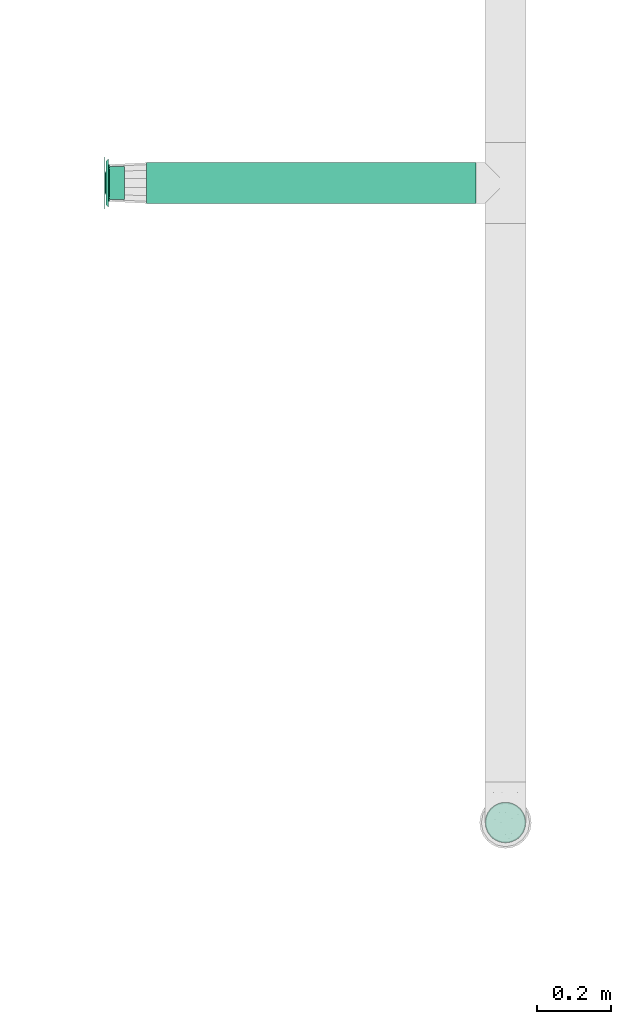
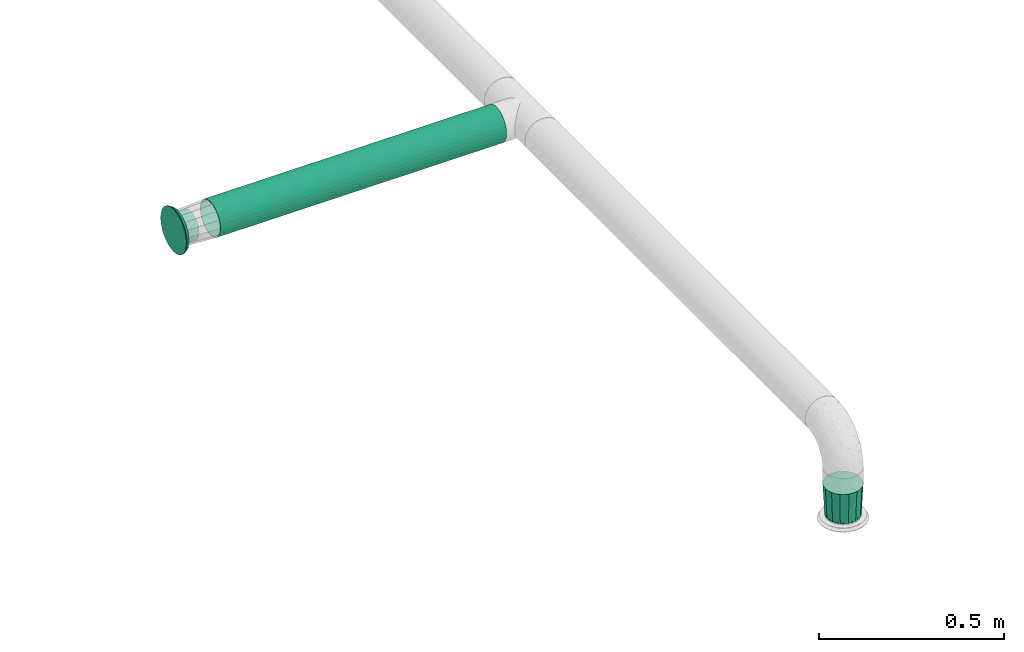
# One storey, part 39 of 115: 1 flow fitting, 1 flow segment, 1 flow terminal.
"""IFC2X3 building model written with IfcOpenShell, lengths in millimetres."""

from ifc_helpers import new_model, entity, si_unit, converted_unit, derived_unit, direction, frame, origin_with_axes, origin_2d_with_axis, place, context, subcontext, project, spatial, hollow_circle, extrude, open_shell, surface_model, source, transform, mapped, material, layer, layer_set, layer_usage, type_object, element, save


model = new_model("IFC2X3")

# Units and contexts
model_context = context("Model", 3, precision=1e-05, world=origin_with_axes(), true_north=direction((0.0, 1.0)))
body_context = subcontext(model_context, "Body", "Model", "MODEL_VIEW")
ifc_project = project(units=[si_unit("AREAUNIT", "SQUARE_METRE"), si_unit("VOLUMEUNIT", "CUBIC_METRE", prefix="DECI"), si_unit("TIMEUNIT", "SECOND"), si_unit("THERMODYNAMICTEMPERATUREUNIT", "DEGREE_CELSIUS"), si_unit("PRESSUREUNIT", "PASCAL"), si_unit("MASSUNIT", "GRAM", prefix="KILO"), si_unit("LENGTHUNIT", "METRE", prefix="MILLI"), si_unit("POWERUNIT", "WATT"), si_unit("ELECTRICCURRENTUNIT", "AMPERE"), si_unit("ELECTRICVOLTAGEUNIT", "VOLT"), derived_unit("VOLUMETRICFLOWRATEUNIT", [(si_unit("VOLUMEUNIT", "CUBIC_METRE", prefix="DECI"), 1), (si_unit("TIMEUNIT", "SECOND"), -1)]), derived_unit("LINEARVELOCITYUNIT", [(si_unit("LENGTHUNIT", "METRE"), 1), (si_unit("TIMEUNIT", "SECOND"), -1)]), derived_unit("MASSDENSITYUNIT", [(si_unit("MASSUNIT", "GRAM", prefix="KILO"), 1), (si_unit("VOLUMEUNIT", "CUBIC_METRE"), -1)]), converted_unit("PLANEANGLEUNIT", "DEGREE", entity("IfcRatioMeasure", 0.01745), si_unit("PLANEANGLEUNIT", "RADIAN"), dimensions=[0, 0, 0, 0, 0, 0, 0])], contexts=[model_context])

# Site, building, storey
site_placement = place(None, origin_with_axes())
site = spatial("IfcSite", under=ifc_project, at=site_placement, CompositionType="ELEMENT")
building_placement = place(site_placement, origin_with_axes())
building = spatial("IfcBuilding", under=site, at=building_placement, Name="mc-building", CompositionType="ELEMENT")
storey_placement = place(building_placement, frame((0.0, 0.0, 2950.0), z_axis=(0.0, 0.0, 1.0), x_axis=(1.0, 0.0, 0.0)))
storey = spatial("IfcBuildingStorey", under=building, at=storey_placement, Name="2. Korrus", CompositionType="ELEMENT", Elevation=2950.0)

# Flow terminal
air_terminal_type = type_object("IfcAirTerminalType", Name="100", PredefinedType="NOTDEFINED")
shared_shape_1 = source(origin_with_axes(), body_context, "Body", "SurfaceModel", [
    surface_model("IfcShellBasedSurfaceModel", [(11.2, 18.11733, -67.61481), (11.2, -18.11733, -67.61481), (11.2, 0.0, -70.0), (11.2, 67.61481, -18.11733), (11.2, 35.0, -60.62178), (11.2, 49.49747, -49.49747), (11.2, 60.62178, -35.0), (11.2, -67.61481, 18.11733), (11.2, -49.49747, -49.49747), (11.2, -67.61481, -18.11733), (11.2, -35.0, -60.62178), (11.2, -60.62178, -35.0), (11.2, -70.0, 0.0), (11.2, 18.11733, 67.61481), (11.2, 70.0, 0.0), (11.2, 67.61481, 18.11733), (11.2, 49.49747, 49.49747), (11.2, 60.62178, 35.0), (11.2, 35.0, 60.62178), (11.2, -49.49747, 49.49747), (11.2, -60.62178, 35.0), (11.2, -35.0, 60.62178), (11.2, -18.11733, 67.61481), (11.2, 0.0, 70.0), (9.2, 18.11733, 67.61481), (9.2, -67.61481, 18.11733), (9.2, 0.0, 70.0), (9.2, 49.49747, 49.49747), (9.2, 35.0, 60.62178), (9.2, 60.62178, 35.0), (9.2, 67.61481, 18.11733), (9.2, -35.0, 60.62178), (9.2, -49.49747, 49.49747), (9.2, -18.11733, 67.61481), (9.2, -60.62178, 35.0), (9.2, -67.61481, -18.11733), (9.2, -70.0, 0.0), (9.2, 67.61481, -18.11733), (9.2, 18.11733, -67.61481), (9.2, 49.49747, -49.49747), (9.2, 60.62178, -35.0), (9.2, 35.0, -60.62178), (9.2, -18.11733, -67.61481), (9.2, -49.49747, -49.49747), (9.2, -60.62178, -35.0), (9.2, -35.0, -60.62178), (9.2, 0.0, -70.0), (9.2, 70.0, 0.0), (9.2, 32.75, 0.0), (9.2, -16.375, 28.36233), (9.2, -28.36233, 16.375), (9.2, 16.375, 28.36233), (9.2, 0.0, 32.75), (9.2, 28.36233, 16.375), (9.2, -32.75, 0.0), (9.2, -16.375, -28.36233), (9.2, 16.375, -28.36233), (9.2, 0.0, -32.75), (9.2, 28.36233, -16.375), (9.2, -28.36233, -16.375), (6.2, -21.19625, -15.39997), (6.2, -21.19625, 15.39997), (6.2, 8.09625, 24.91768), (6.2, -8.09625, 24.91768), (6.2, -26.2, 0.0), (6.2, 21.19625, 15.39997), (6.2, -8.09625, -24.91768), (6.2, 21.19625, -15.39997), (6.2, 8.09625, -24.91768), (6.2, 26.2, 0.0), (9.2, 31.06579, -6.28555), (6.2, 23.69812, -7.69999), (6.2, -14.64625, -20.15883), (9.2, -22.36867, -22.36867), (6.2, -23.69812, -7.69999), (9.2, -31.06579, -6.28555), (6.2, 14.64625, -20.15883), (9.2, 8.1875, -30.55617), (6.2, 0.0, -24.91768), (9.2, 22.36867, -22.36867), (9.2, -8.1875, -30.55617), (9.2, -31.06579, 6.28555), (6.2, -23.69812, 7.69999), (6.2, 14.64625, 20.15883), (9.2, 22.36867, 22.36867), (6.2, 23.69812, 7.69999), (9.2, 31.06579, 6.28555), (6.2, -14.64625, 20.15883), (9.2, -8.1875, 30.55617), (6.2, 0.0, 24.91768), (9.2, -22.36867, 22.36867), (9.2, 8.1875, 30.55617), (6.2, -13.11761, 57.472), (6.2, -36.75472, 46.08897), (6.2, -53.11211, 25.57744), (6.2, 36.75472, 46.08897), (6.2, -58.95, 0.0), (6.2, 13.11761, 57.472), (6.2, 53.11211, 25.57744), (6.2, -53.11211, -25.57744), (6.2, -36.75472, -46.08897), (6.2, -13.11761, -57.472), (6.2, 58.95, 0.0), (6.2, 53.11211, -25.57744), (6.2, 13.11761, -57.472), (6.2, 36.75472, -46.08897), (0.0, -60.51411, 25.06576), (0.0, 0.0, 65.5), (0.0, 25.06576, 60.51411), (0.0, 46.3155, 46.3155), (0.0, 60.51411, 25.06576), (0.0, -46.3155, 46.3155), (0.0, -25.06576, 60.51411), (0.0, 0.0, -65.5), (0.0, -65.5, 0.0), (0.0, 65.5, 0.0), (0.0, 60.51411, -25.06576), (0.0, 46.3155, -46.3155), (0.0, 25.06576, -60.51411), (0.0, -46.3155, -46.3155), (0.0, -60.51411, -25.06576), (0.0, -25.06576, -60.51411), (6.2, 56.03105, -12.78872), (0.0, 53.4148, -35.69063), (0.0, 35.69063, -53.4148), (6.2, 24.93616, -51.78048), (0.0, -12.53288, -63.00706), (6.2, 0.0, -57.472), (0.0, -35.69063, -53.4148), (0.0, 63.00706, -12.53288), (6.2, 44.93342, -35.83321), (6.2, -24.93616, -51.78048), (6.2, -44.93342, -35.83321), (0.0, -53.4148, -35.69063), (0.0, 12.53288, -63.00706), (6.2, -56.03105, -12.78872), (0.0, -63.00706, -12.53288), (6.2, -56.03105, 12.78872), (0.0, -53.4148, 35.69063), (0.0, -35.69063, 53.4148), (6.2, -24.93616, 51.78048), (0.0, 12.53288, 63.00706), (6.2, 0.0, 57.472), (0.0, 35.69063, 53.4148), (0.0, -63.00706, 12.53288), (6.2, -44.93342, 35.83321), (6.2, 24.93616, 51.78048), (6.2, 44.93342, 35.83321), (0.0, 53.4148, 35.69063), (0.0, -12.53288, 63.00706), (6.2, 56.03105, 12.78872), (0.0, 63.00706, 12.53288), (-3.1, 12.94095, 48.29629), (-3.1, -35.35534, 35.35534), (-3.1, 0.0, 50.0), (-3.1, 35.35534, 35.35534), (-3.1, 25.0, 43.30127), (-3.1, -43.30127, 25.0), (-3.1, 43.30127, 25.0), (-3.1, -48.29629, -12.94095), (-3.1, -12.94095, 48.29629), (-3.1, -25.0, 43.30127), (-3.1, -50.0, 0.0), (-3.1, -48.29629, 12.94095), (-3.1, 48.29629, 12.94095), (-3.1, 12.94095, -48.29629), (-3.1, 50.0, 0.0), (-3.1, 48.29629, -12.94095), (-3.1, 35.35534, -35.35534), (-3.1, 43.30127, -25.0), (-3.1, 25.0, -43.30127), (-3.1, 0.0, -50.0), (-3.1, -35.35534, -35.35534), (-3.1, -43.30127, -25.0), (-3.1, -25.0, -43.30127), (-3.1, -12.94095, -48.29629), (0.0, 25.0, -43.30127), (0.0, 0.0, -50.0), (0.0, 12.94095, -48.29629), (0.0, 48.29629, -12.94095), (0.0, 35.35534, -35.35534), (0.0, -25.0, -43.30127), (0.0, 43.30127, -25.0), (0.0, -50.0, 0.0), (0.0, -12.94095, -48.29629), (0.0, -35.35534, -35.35534), (0.0, -48.29629, -12.94095), (0.0, -43.30127, -25.0), (0.0, 50.0, 0.0), (0.0, 43.30127, 25.0), (0.0, 12.94095, 48.29629), (0.0, 35.35534, 35.35534), (0.0, 25.0, 43.30127), (0.0, 0.0, 50.0), (0.0, -35.35534, 35.35534), (0.0, -43.30127, 25.0), (0.0, -48.29629, 12.94095), (0.0, -12.94095, 48.29629), (0.0, -25.0, 43.30127), (0.0, 48.29629, 12.94095), (-43.1, 0.0, 45.0), (-43.1, 11.64686, 43.46666), (-43.1, 22.5, 38.97115), (-43.1, -11.64686, 43.46666), (-43.1, 38.97115, 22.5), (-43.1, 43.46666, 11.64686), (-43.1, 31.81981, 31.81981), (-43.1, -22.5, 38.97115), (-43.1, -43.46666, 11.64686), (-43.1, -31.81981, 31.81981), (-43.1, -38.97115, 22.5), (-43.1, -45.0, 0.0), (-43.1, -43.46666, -11.64686), (-43.1, 45.0, 0.0), (-43.1, 43.46666, -11.64686), (-43.1, 38.97115, -22.5), (-43.1, 31.81981, -31.81981), (-43.1, 22.5, -38.97115), (-43.1, 11.64686, -43.46666), (-43.1, -31.81981, -31.81981), (-43.1, -38.97115, -22.5), (-43.1, -22.5, -38.97115), (-43.1, 0.0, -45.0), (-43.1, -11.64686, -43.46666), (-3.1, 22.5, -38.97115), (-3.1, 0.0, -45.0), (-3.1, 11.64686, -43.46666), (-3.1, 31.81981, -31.81981), (-3.1, -22.5, -38.97115), (-3.1, 38.97115, -22.5), (-3.1, 43.46666, -11.64686), (-3.1, 45.0, 0.0), (-3.1, -45.0, 0.0), (-3.1, -11.64686, -43.46666), (-3.1, -31.81981, -31.81981), (-3.1, -43.46666, -11.64686), (-3.1, -38.97115, -22.5), (-3.1, 0.0, 45.0), (-3.1, 43.46666, 11.64686), (-3.1, 38.97115, 22.5), (-3.1, 22.5, 38.97115), (-3.1, 31.81981, 31.81981), (-3.1, 11.64686, 43.46666), (-3.1, -11.64686, 43.46666), (-3.1, -43.46666, 11.64686), (-3.1, -31.81981, 31.81981), (-3.1, -38.97115, 22.5), (-3.1, -22.5, 38.97115)], [open_shell([[[0, 1, 2]], [[3, 0, 4]], [[5, 6, 3]], [[5, 3, 4]], [[7, 1, 0]], [[8, 7, 9]], [[10, 7, 8]], [[8, 9, 11]], [[12, 9, 7]], [[1, 7, 10]], [[7, 0, 3]], [[13, 14, 15]], [[16, 15, 17]], [[16, 18, 13]], [[16, 13, 15]], [[14, 13, 7]], [[7, 19, 20]], [[19, 7, 21]], [[7, 22, 21]], [[22, 7, 23]], [[7, 13, 23]], [[14, 7, 3]], [[24, 25, 26]], [[27, 24, 28]], [[27, 29, 30]], [[27, 30, 24]], [[25, 24, 30]], [[31, 25, 32]], [[25, 31, 33]], [[32, 25, 34]], [[33, 26, 25]], [[25, 35, 36]], [[25, 30, 37]], [[25, 37, 38]], [[39, 37, 40]], [[39, 41, 38]], [[39, 38, 37]], [[38, 42, 25]], [[35, 43, 44]], [[35, 25, 43]], [[45, 43, 25]], [[42, 45, 25]], [[38, 46, 42]], [[37, 30, 47]], [[35, 9, 36]], [[44, 11, 35]], [[10, 43, 45]], [[44, 43, 8]], [[1, 45, 42]], [[35, 11, 9]], [[9, 12, 36]], [[1, 10, 45]], [[8, 43, 10]], [[8, 11, 44]], [[2, 1, 42]], [[42, 46, 2]], [[38, 0, 46]], [[41, 4, 38]], [[6, 39, 40]], [[41, 39, 5]], [[3, 40, 37]], [[41, 5, 4]], [[4, 0, 38]], [[14, 3, 37]], [[6, 40, 3]], [[6, 5, 39]], [[47, 14, 37]], [[46, 0, 2]], [[30, 15, 47]], [[29, 17, 30]], [[18, 27, 28]], [[29, 27, 16]], [[13, 28, 24]], [[30, 17, 15]], [[15, 14, 47]], [[13, 18, 28]], [[16, 27, 18]], [[16, 17, 29]], [[23, 13, 24]], [[24, 26, 23]], [[33, 22, 26]], [[31, 21, 33]], [[20, 32, 34]], [[31, 32, 19]], [[7, 34, 25]], [[31, 19, 21]], [[21, 22, 33]], [[12, 7, 25]], [[20, 34, 7]], [[20, 19, 32]], [[36, 12, 25]], [[26, 22, 23]], [[48, 49, 50]], [[48, 51, 49]], [[49, 51, 52]], [[53, 51, 48]], [[48, 50, 54]], [[54, 55, 48]], [[56, 55, 57]], [[55, 58, 48]], [[58, 55, 56]], [[55, 54, 59]], [[60, 61, 62]], [[62, 61, 63]], [[64, 61, 60]], [[62, 65, 66]], [[67, 68, 65]], [[66, 60, 62]], [[65, 68, 66]], [[69, 67, 65]], [[69, 48, 70]], [[58, 71, 70]], [[72, 73, 60]], [[59, 74, 60]], [[75, 64, 74]], [[56, 68, 76]], [[72, 66, 55]], [[73, 72, 55]], [[68, 77, 78]], [[64, 75, 54]], [[59, 75, 74]], [[70, 71, 69]], [[67, 79, 76]], [[80, 55, 66]], [[68, 56, 77]], [[56, 76, 79]], [[79, 67, 58]], [[71, 58, 67]], [[80, 78, 57]], [[77, 57, 78]], [[66, 78, 80]], [[59, 60, 73]], [[64, 54, 81]], [[50, 82, 81]], [[83, 84, 65]], [[53, 85, 65]], [[86, 69, 85]], [[49, 63, 87]], [[83, 62, 51]], [[84, 83, 51]], [[63, 88, 89]], [[69, 86, 48]], [[53, 86, 85]], [[81, 82, 64]], [[61, 90, 87]], [[91, 51, 62]], [[63, 49, 88]], [[49, 87, 90]], [[90, 61, 50]], [[82, 50, 61]], [[91, 89, 52]], [[88, 52, 89]], [[62, 89, 91]], [[53, 65, 84]], [[92, 93, 94]], [[95, 94, 96]], [[97, 92, 95]], [[95, 92, 94]], [[96, 98, 95]], [[96, 99, 98]], [[99, 100, 101]], [[101, 102, 98]], [[102, 101, 103]], [[104, 105, 103]], [[101, 104, 103]], [[101, 98, 99]], [[106, 107, 108]], [[109, 110, 108]], [[106, 108, 110]], [[111, 112, 106]], [[106, 112, 107]], [[106, 113, 114]], [[106, 110, 113]], [[115, 116, 117]], [[117, 113, 110]], [[113, 117, 118]], [[114, 119, 120]], [[121, 119, 114]], [[121, 114, 113]], [[115, 117, 110]], [[103, 116, 122]], [[123, 116, 103]], [[124, 125, 118]], [[101, 126, 127]], [[100, 119, 128]], [[102, 122, 129]], [[103, 130, 123]], [[102, 129, 115]], [[113, 127, 126]], [[125, 124, 105]], [[130, 105, 117]], [[118, 125, 104]], [[124, 117, 105]], [[131, 100, 128]], [[119, 100, 132]], [[133, 99, 120]], [[134, 118, 104]], [[122, 116, 129]], [[127, 134, 104]], [[131, 121, 101]], [[99, 133, 132]], [[128, 121, 131]], [[130, 117, 123]], [[101, 121, 126]], [[99, 135, 120]], [[96, 136, 135]], [[136, 120, 135]], [[134, 127, 113]], [[133, 119, 132]], [[136, 96, 114]], [[94, 106, 137]], [[138, 106, 94]], [[139, 140, 112]], [[97, 141, 142]], [[95, 109, 143]], [[96, 137, 144]], [[94, 145, 138]], [[96, 144, 114]], [[107, 142, 141]], [[140, 139, 93]], [[145, 93, 111]], [[112, 140, 92]], [[139, 111, 93]], [[146, 95, 143]], [[109, 95, 147]], [[148, 98, 110]], [[149, 112, 92]], [[137, 106, 144]], [[142, 149, 92]], [[146, 108, 97]], [[98, 148, 147]], [[143, 108, 146]], [[145, 111, 138]], [[97, 108, 141]], [[98, 150, 110]], [[102, 151, 150]], [[151, 110, 150]], [[149, 142, 107]], [[148, 109, 147]], [[151, 102, 115]], [[152, 153, 154]], [[155, 152, 156]], [[157, 152, 158]], [[158, 152, 155]], [[158, 159, 157]], [[160, 153, 161]], [[160, 154, 153]], [[157, 162, 163]], [[153, 152, 157]], [[157, 159, 162]], [[158, 164, 159]], [[165, 166, 167]], [[168, 167, 169]], [[170, 165, 167]], [[170, 167, 168]], [[166, 165, 171]], [[159, 172, 173]], [[172, 159, 174]], [[174, 171, 175]], [[159, 164, 174]], [[166, 171, 174]], [[174, 164, 166]], [[176, 177, 178]], [[179, 176, 180]], [[176, 179, 181]], [[179, 180, 182]], [[179, 183, 181]], [[177, 181, 184]], [[177, 176, 181]], [[185, 186, 187]], [[186, 185, 181]], [[181, 183, 186]], [[183, 179, 188]], [[183, 188, 189]], [[190, 189, 191]], [[189, 190, 183]], [[190, 191, 192]], [[193, 194, 190]], [[183, 195, 196]], [[183, 190, 195]], [[194, 197, 198]], [[194, 195, 190]], [[197, 194, 193]], [[189, 188, 199]], [[164, 199, 166]], [[158, 189, 164]], [[192, 155, 156]], [[158, 155, 191]], [[190, 156, 152]], [[164, 189, 199]], [[199, 188, 166]], [[190, 192, 156]], [[191, 155, 192]], [[191, 189, 158]], [[193, 190, 152]], [[152, 154, 193]], [[160, 197, 154]], [[161, 198, 160]], [[195, 153, 157]], [[161, 153, 194]], [[196, 157, 163]], [[161, 194, 198]], [[198, 197, 160]], [[183, 196, 163]], [[195, 157, 196]], [[195, 194, 153]], [[162, 183, 163]], [[154, 197, 193]], [[159, 186, 162]], [[173, 187, 159]], [[181, 172, 174]], [[173, 172, 185]], [[184, 174, 175]], [[159, 187, 186]], [[186, 183, 162]], [[184, 181, 174]], [[185, 172, 181]], [[185, 187, 173]], [[177, 184, 175]], [[175, 171, 177]], [[165, 178, 171]], [[170, 176, 165]], [[182, 168, 169]], [[170, 168, 180]], [[179, 169, 167]], [[170, 180, 176]], [[176, 178, 165]], [[188, 179, 167]], [[182, 169, 179]], [[182, 180, 168]], [[166, 188, 167]], [[171, 178, 177]], [[200, 201, 202]], [[203, 200, 202]], [[204, 205, 202]], [[204, 202, 206]], [[203, 202, 205]], [[207, 208, 209]], [[207, 203, 205]], [[209, 208, 210]], [[211, 208, 212]], [[208, 207, 212]], [[207, 205, 212]], [[213, 214, 215]], [[205, 215, 212]], [[212, 216, 217]], [[216, 212, 215]], [[218, 219, 217]], [[212, 219, 220]], [[212, 217, 219]], [[221, 222, 223]], [[222, 221, 219]], [[218, 222, 219]], [[215, 205, 213]], [[224, 225, 226]], [[227, 228, 224]], [[229, 230, 231]], [[228, 227, 229]], [[229, 232, 228]], [[225, 228, 233]], [[225, 224, 228]], [[234, 235, 236]], [[235, 234, 228]], [[228, 232, 235]], [[232, 229, 231]], [[237, 238, 239]], [[240, 239, 241]], [[240, 242, 237]], [[240, 237, 239]], [[238, 237, 243]], [[244, 245, 246]], [[247, 244, 232]], [[244, 247, 245]], [[232, 238, 247]], [[238, 243, 247]], [[238, 232, 231]], [[205, 238, 213]], [[204, 239, 205]], [[240, 206, 202]], [[204, 206, 241]], [[242, 202, 201]], [[205, 239, 238]], [[238, 231, 213]], [[240, 202, 242]], [[241, 206, 240]], [[241, 239, 204]], [[201, 237, 242]], [[201, 200, 237]], [[243, 203, 207]], [[209, 247, 207]], [[246, 210, 208]], [[209, 210, 245]], [[244, 208, 211]], [[203, 243, 200]], [[207, 247, 243]], [[200, 243, 237]], [[209, 245, 247]], [[210, 246, 245]], [[244, 246, 208]], [[211, 232, 244]], [[212, 235, 211]], [[220, 236, 212]], [[228, 219, 221]], [[220, 219, 234]], [[233, 221, 223]], [[212, 236, 235]], [[235, 232, 211]], [[233, 228, 221]], [[234, 219, 228]], [[234, 236, 220]], [[225, 233, 223]], [[223, 222, 225]], [[226, 218, 217]], [[216, 224, 217]], [[229, 215, 214]], [[216, 215, 227]], [[230, 214, 213]], [[218, 226, 222]], [[217, 224, 226]], [[222, 226, 225]], [[216, 227, 224]], [[215, 229, 227]], [[230, 229, 214]], [[213, 231, 230]]])]),
])
flow_terminal_placement = place(storey_placement, frame((6894.2807, 9915.0, 2465.0), z_axis=(0.0, 0.0, 1.0), x_axis=(-1.0, 0.0, 0.0)))
element("IfcFlowTerminal", 1, at=flow_terminal_placement, inside=storey, type_object=air_terminal_type, Name="100", context=body_context, shape_type="MappedRepresentation", body=[
    mapped(shared_shape_1, transform((0.0, 0.0, 0.0), scale=1.0)),
])

# Flow fitting
duct_fitting_type = type_object("IfcDuctFittingType", PredefinedType="TRANSITION")
shared_shape_2 = source(origin_with_axes(), body_context, "Body", "SurfaceModel", [
    surface_model("IfcShellBasedSurfaceModel", [(0.0, 12.94095, 48.29629), (0.0, -35.35534, 35.35534), (0.0, 0.0, 50.0), (0.0, 35.35534, 35.35534), (0.0, 25.0, 43.30127), (0.0, 43.30127, 25.0), (0.0, 48.29629, 12.94095), (0.0, -12.94095, 48.29629), (0.0, -25.0, 43.30127), (0.0, -48.29629, 12.94095), (0.0, -43.30127, 25.0), (0.0, -25.0, -43.30127), (0.0, -48.29629, -12.94095), (0.0, -50.0, 0.0), (0.0, 48.29629, -12.94095), (0.0, 12.94095, -48.29629), (0.0, 43.30127, -25.0), (0.0, 35.35534, -35.35534), (0.0, 25.0, -43.30127), (0.0, -35.35534, -35.35534), (0.0, -43.30127, -25.0), (0.0, -12.94095, -48.29629), (0.0, 0.0, -50.0), (0.0, 50.0, 0.0), (100.0, -55.0, 0.0), (100.0, -12.23865, 53.62104), (100.0, -34.29194, 43.00073), (100.0, 49.55329, -23.86361), (100.0, 12.23865, 53.62104), (100.0, 34.29194, 43.00073), (100.0, 55.0, 0.0), (100.0, 49.55329, 23.86361), (100.0, -49.55329, 23.86361), (100.0, 12.23865, -53.62104), (100.0, -49.55329, -23.86361), (100.0, -34.29194, -43.00073), (100.0, 34.29194, -43.00073), (100.0, -12.23865, -53.62104), (0.0, 11.12605, 48.7464), (0.0, -11.12605, 48.7464), (0.0, 31.17449, 39.09157), (0.0, -45.04844, -21.69419), (0.0, -45.04844, 21.69419), (0.0, -31.17449, 39.09157), (0.0, 45.04844, 21.69419), (0.0, 45.04844, -21.69419), (0.0, 31.17449, -39.09157), (0.0, -31.17449, -39.09157), (0.0, -11.12605, -48.7464), (0.0, 11.12605, -48.7464), (0.0, -47.52422, -10.84709), (100.0, -41.92261, -33.43217), (0.0, -38.11147, -30.39288), (100.0, 41.92261, -33.43217), (0.0, 38.11147, -30.39288), (0.0, -21.15027, -43.91899), (100.0, -23.2653, -48.31088), (100.0, -52.32388, -11.72483), (100.0, 0.0, -53.62104), (0.0, 0.0, -48.7464), (100.0, 23.2653, -48.31088), (0.0, 21.15027, -43.91899), (100.0, 52.32388, -11.72483), (0.0, 47.52422, -10.84709), (0.0, 47.52422, 10.84709), (100.0, 41.92261, 33.43217), (0.0, 38.11147, 30.39288), (100.0, -41.92261, 33.43217), (0.0, -38.11147, 30.39288), (0.0, 21.15027, 43.91899), (100.0, 23.2653, 48.31088), (100.0, 52.32388, 11.72483), (100.0, 0.0, 53.62104), (0.0, 0.0, 48.7464), (100.0, -23.2653, 48.31088), (0.0, -21.15027, 43.91899), (100.0, -52.32388, 11.72483), (0.0, -47.52422, 10.84709), (100.0, 27.5, -47.63139), (100.0, 0.0, -55.0), (100.0, 14.23505, -53.12592), (100.0, 38.89087, -38.89087), (100.0, -27.5, -47.63139), (100.0, 47.63139, -27.5), (100.0, 53.12592, -14.23505), (100.0, -14.23505, -53.12592), (100.0, -47.63139, -27.5), (100.0, -38.89087, -38.89087), (100.0, -53.12592, -14.23505), (100.0, 53.12592, 14.23505), (100.0, 47.63139, 27.5), (100.0, 27.5, 47.63139), (100.0, 38.89087, 38.89087), (100.0, 14.23505, 53.12592), (100.0, 0.0, 55.0), (100.0, -47.63139, 27.5), (100.0, -53.12592, 14.23505), (100.0, -27.5, 47.63139), (100.0, -38.89087, 38.89087), (100.0, -14.23505, 53.12592), (98.0, 0.0, 55.0), (98.0, 14.23505, 53.12592), (98.0, 27.5, 47.63139), (98.0, 38.89087, 38.89087), (98.0, 47.63139, 27.5), (98.0, -47.63139, 27.5), (98.0, 53.12592, -14.23505), (98.0, -27.5, 47.63139), (98.0, -14.23505, 53.12592), (98.0, -38.89087, 38.89087), (98.0, -55.0, 0.0), (98.0, -53.12592, 14.23505), (98.0, 53.12592, 14.23505), (98.0, 47.63139, -27.5), (98.0, -27.5, -47.63139), (98.0, 0.0, -55.0), (98.0, 38.89087, -38.89087), (98.0, 27.5, -47.63139), (98.0, 14.23505, -53.12592), (98.0, -47.63139, -27.5), (98.0, -38.89087, -38.89087), (98.0, -53.12592, -14.23505), (98.0, -14.23505, -53.12592), (98.0, 55.0, 0.0), (2.0, 12.94095, -48.29629), (2.0, 25.0, -43.30127), (2.0, 35.35534, -35.35534), (2.0, 43.30127, -25.0), (2.0, 48.29629, -12.94095), (2.0, 0.0, -50.0), (2.0, 50.0, 0.0), (2.0, -25.0, -43.30127), (2.0, -12.94095, -48.29629), (2.0, -35.35534, -35.35534), (2.0, -48.29629, -12.94095), (2.0, -43.30127, -25.0), (2.0, -48.29629, 12.94095), (2.0, 48.29629, 12.94095), (2.0, 43.30127, 25.0), (2.0, 35.35534, 35.35534), (2.0, -35.35534, 35.35534), (2.0, 12.94095, 48.29629), (2.0, 25.0, 43.30127), (2.0, 0.0, 50.0), (2.0, -43.30127, 25.0), (2.0, -50.0, 0.0), (2.0, -12.94095, 48.29629), (2.0, -25.0, 43.30127)], [open_shell([[[0, 1, 2]], [[3, 0, 4]], [[3, 5, 6]], [[0, 3, 1]], [[6, 1, 3]], [[7, 1, 8]], [[7, 2, 1]], [[1, 9, 10]], [[9, 1, 11]], [[12, 13, 9]], [[11, 1, 6]], [[6, 14, 11]], [[15, 14, 16]], [[17, 18, 15]], [[17, 15, 16]], [[11, 14, 15]], [[12, 19, 20]], [[19, 12, 11]], [[15, 21, 11]], [[12, 9, 11]], [[22, 21, 15]], [[14, 6, 23]], [[24, 25, 26]], [[25, 27, 28]], [[29, 28, 27]], [[27, 30, 31]], [[31, 29, 27]], [[24, 26, 32]], [[33, 24, 34]], [[33, 34, 35]], [[36, 27, 33]], [[33, 27, 24]], [[35, 37, 33]], [[24, 27, 25]], [[38, 23, 39]], [[40, 23, 38]], [[41, 42, 43]], [[41, 13, 42]], [[23, 43, 39]], [[40, 44, 23]], [[41, 23, 45]], [[41, 45, 46]], [[47, 41, 48]], [[49, 48, 41]], [[41, 46, 49]], [[23, 41, 43]], [[34, 50, 41]], [[47, 51, 52]], [[45, 27, 53]], [[36, 54, 53]], [[55, 48, 56]], [[34, 57, 50]], [[57, 13, 50]], [[13, 57, 24]], [[55, 35, 47]], [[35, 51, 47]], [[51, 41, 52]], [[58, 59, 49]], [[60, 61, 46]], [[37, 59, 58]], [[62, 63, 23]], [[35, 55, 56]], [[23, 30, 62]], [[53, 54, 45]], [[48, 37, 56]], [[33, 49, 61]], [[49, 33, 58]], [[54, 36, 46]], [[63, 27, 45]], [[34, 41, 51]], [[33, 61, 60]], [[48, 59, 37]], [[27, 63, 62]], [[46, 36, 60]], [[31, 64, 44]], [[40, 65, 66]], [[42, 32, 67]], [[26, 68, 67]], [[69, 38, 70]], [[31, 71, 64]], [[71, 23, 64]], [[23, 71, 30]], [[69, 29, 40]], [[29, 65, 40]], [[65, 44, 66]], [[72, 73, 39]], [[74, 75, 43]], [[28, 73, 72]], [[76, 77, 13]], [[29, 69, 70]], [[13, 24, 76]], [[67, 68, 42]], [[38, 28, 70]], [[25, 39, 75]], [[39, 25, 72]], [[68, 26, 43]], [[77, 32, 42]], [[31, 44, 65]], [[25, 75, 74]], [[38, 73, 28]], [[32, 77, 76]], [[43, 26, 74]], [[78, 79, 80]], [[81, 82, 78]], [[82, 83, 84]], [[81, 83, 82]], [[30, 82, 84]], [[79, 82, 85]], [[79, 78, 82]], [[82, 86, 87]], [[82, 30, 86]], [[24, 88, 86]], [[86, 30, 89]], [[90, 24, 89]], [[91, 90, 92]], [[91, 93, 94]], [[90, 91, 24]], [[94, 95, 91]], [[24, 95, 96]], [[24, 91, 95]], [[94, 97, 98]], [[98, 95, 94]], [[97, 94, 99]], [[89, 24, 86]], [[100, 101, 102]], [[100, 102, 103]], [[100, 104, 105]], [[104, 100, 103]], [[106, 105, 104]], [[100, 107, 108]], [[100, 109, 107]], [[105, 110, 111]], [[109, 100, 105]], [[105, 106, 110]], [[106, 104, 112]], [[106, 113, 110]], [[113, 114, 110]], [[115, 116, 117]], [[113, 116, 115]], [[117, 118, 115]], [[119, 114, 120]], [[121, 110, 119]], [[114, 115, 122]], [[119, 110, 114]], [[115, 114, 113]], [[123, 106, 112]], [[121, 88, 110]], [[119, 86, 121]], [[82, 120, 114]], [[119, 120, 87]], [[85, 114, 122]], [[121, 86, 88]], [[88, 24, 110]], [[85, 82, 114]], [[87, 120, 82]], [[87, 86, 119]], [[79, 85, 122]], [[122, 115, 79]], [[118, 80, 115]], [[117, 78, 118]], [[83, 116, 113]], [[117, 116, 81]], [[84, 113, 106]], [[117, 81, 78]], [[78, 80, 118]], [[30, 84, 106]], [[83, 113, 84]], [[83, 81, 116]], [[123, 30, 106]], [[115, 80, 79]], [[112, 89, 123]], [[104, 90, 112]], [[91, 103, 102]], [[104, 103, 92]], [[93, 102, 101]], [[112, 90, 89]], [[89, 30, 123]], [[93, 91, 102]], [[92, 103, 91]], [[92, 90, 104]], [[94, 93, 101]], [[101, 100, 94]], [[108, 99, 100]], [[107, 97, 108]], [[95, 109, 105]], [[107, 109, 98]], [[96, 105, 111]], [[107, 98, 97]], [[97, 99, 108]], [[24, 96, 111]], [[95, 105, 96]], [[95, 98, 109]], [[110, 24, 111]], [[100, 99, 94]], [[124, 125, 126]], [[124, 126, 127]], [[124, 128, 129]], [[128, 124, 127]], [[129, 128, 130]], [[129, 131, 132]], [[129, 130, 131]], [[133, 134, 135]], [[134, 133, 131]], [[131, 136, 134]], [[131, 130, 137]], [[137, 138, 139]], [[140, 137, 139]], [[140, 139, 141]], [[141, 139, 142]], [[140, 141, 143]], [[136, 140, 144]], [[145, 134, 136]], [[140, 146, 147]], [[131, 140, 136]], [[143, 146, 140]], [[131, 137, 140]], [[12, 134, 13]], [[20, 135, 12]], [[131, 19, 11]], [[20, 19, 133]], [[132, 11, 21]], [[12, 135, 134]], [[134, 145, 13]], [[132, 131, 11]], [[133, 19, 131]], [[133, 135, 20]], [[129, 132, 21]], [[21, 22, 129]], [[15, 124, 22]], [[18, 125, 15]], [[127, 17, 16]], [[18, 17, 126]], [[128, 16, 14]], [[18, 126, 125]], [[125, 124, 15]], [[130, 128, 14]], [[127, 16, 128]], [[127, 126, 17]], [[23, 130, 14]], [[22, 124, 129]], [[6, 137, 23]], [[5, 138, 6]], [[142, 3, 4]], [[5, 3, 139]], [[141, 4, 0]], [[6, 138, 137]], [[137, 130, 23]], [[141, 142, 4]], [[139, 3, 142]], [[139, 138, 5]], [[143, 141, 0]], [[0, 2, 143]], [[7, 146, 2]], [[8, 147, 7]], [[144, 1, 10]], [[8, 1, 140]], [[136, 10, 9]], [[8, 140, 147]], [[147, 146, 7]], [[145, 136, 9]], [[144, 10, 136]], [[144, 140, 1]], [[13, 145, 9]], [[2, 146, 143]]])]),
])
flow_fitting_placement = place(storey_placement, frame((7969.21808, 8183.57591, 2203.1), z_axis=(0.0, 1.0, 0.0), x_axis=(0.0, 0.0, 1.0)))
element("IfcFlowFitting", 2, at=flow_fitting_placement, inside=storey, type_object=duct_fitting_type, context=body_context, shape_type="MappedRepresentation", body=[
    mapped(shared_shape_2, transform((0.0, 0.0, 0.0), scale=1.0)),
])

# Flow segment
ifc_material = material(Name="FZ1")
ifc_layer = layer(ifc_material, 0.0)
ifc_layer_set = layer_set([ifc_layer], Name="FZ1")
ifc_layer_usage = layer_usage(ifc_layer_set, "AXIS1", "POSITIVE", 0.0)
duct_segment_type = type_object("IfcDuctSegmentType", PredefinedType="RIGIDSEGMENT")
shared_shape_3 = source(origin_with_axes(), body_context, "Body", "SweptSolid", [
    extrude(hollow_circle(Radius=55.0, WallThickness=2.0, at=origin_2d_with_axis()), frame((0.0, 0.0, 0.0), z_axis=(1.0, 0.0, 0.0), x_axis=(0.0, 1.0, 0.0)), (0.0, 0.0, 1.0), 891.8),
])
flow_segment_placement = place(storey_placement, frame((7889.21808, 9915.0, 2465.0), z_axis=(0.0, 0.0, 1.0), x_axis=(-1.0, 0.0, 0.0)))
element("IfcFlowSegment", 3, at=flow_segment_placement, inside=storey, type_object=duct_segment_type, material=ifc_layer_usage, context=body_context, shape_type="MappedRepresentation", body=[
    mapped(shared_shape_3, transform((0.0, 0.0, 0.0), scale=1.0)),
])

save(model, "model.ifc")
